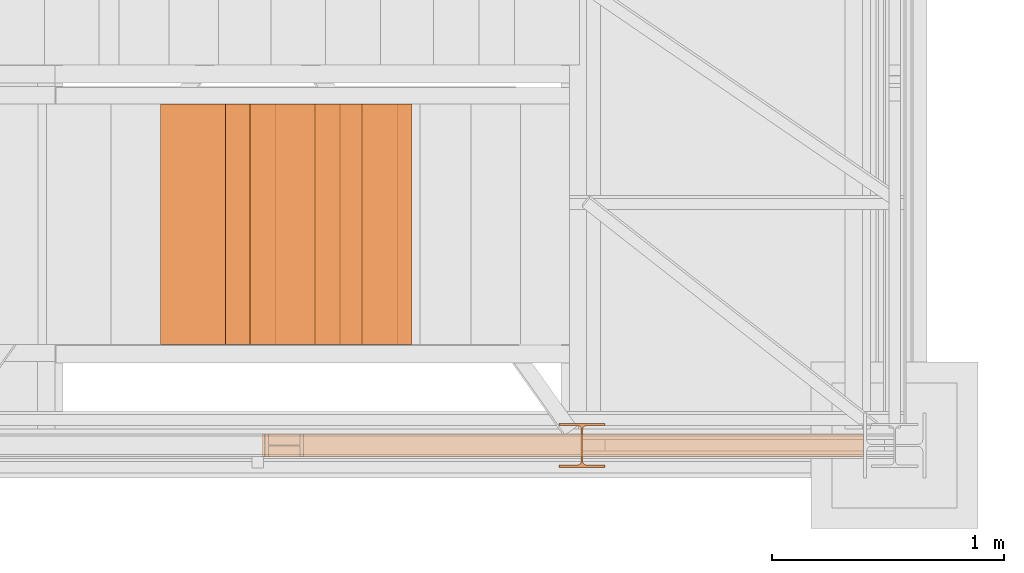
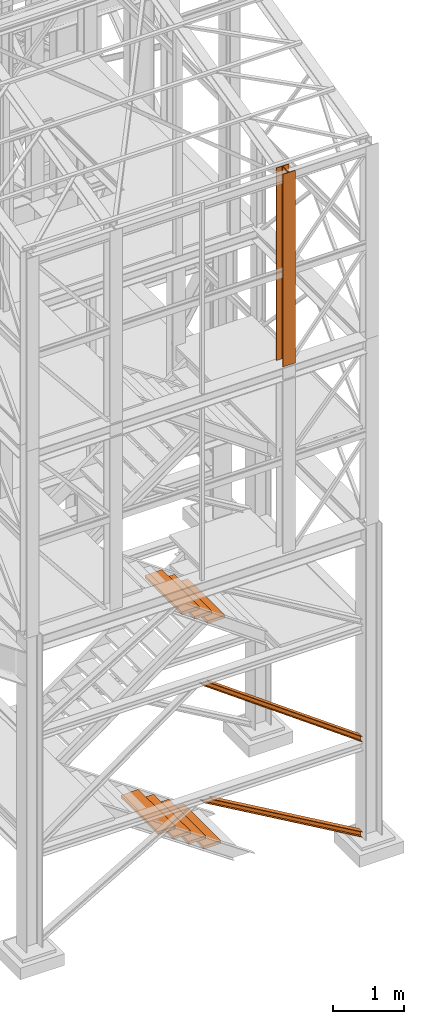
# One storey, part 44 of 208: 10 proxies.
"""IFC2X3 building model written with IfcOpenShell, lengths in millimetres."""

from ifc_helpers import new_model, entity, si_unit, converted_unit, frame, origin, origin_with_axes, place, context, subcontext, project, spatial, faceted_brep, element, save


model = new_model("IFC2X3")

# Units and contexts
model_context = context("Model", 3, precision=1e-05, world=origin())
plan_context = context("Plan", 3, precision=1e-05, world=origin())
body_context = subcontext(model_context, "Body", "Model", "MODEL_VIEW")
ifc_project = project(units=[si_unit("LENGTHUNIT", "METRE", prefix="MILLI"), converted_unit("PLANEANGLEUNIT", "DEGREE", entity("IfcPlaneAngleMeasure", 0.0174532925199433), si_unit("PLANEANGLEUNIT", "RADIAN"), dimensions=[0, 0, 0, 0, 0, 0, 0]), si_unit("AREAUNIT", "SQUARE_METRE"), si_unit("VOLUMEUNIT", "CUBIC_METRE")], contexts=[model_context, plan_context])

# Building, storey
building_placement = place(None, origin())
building = spatial("IfcBuilding", under=ifc_project, at=building_placement, CompositionType="COMPLEX")
storey_placement = place(building_placement, origin_with_axes())
storey = spatial("IfcBuildingStorey", under=building, at=storey_placement, Name="Geschoss", CompositionType="ELEMENT")

# Proxies
proxy_1_placement = place(storey_placement, frame((4333.540323586694, -24736.51916887601, 4082.443433237497), z_axis=(0.0, 0.0, 1.0), x_axis=(1.0, 0.0, 0.0)))
element("IfcBuildingElementProxy", 1, at=proxy_1_placement, inside=storey, context=body_context, shape_type="Brep", body=[
    faceted_brep([(0.009999999999308784, 0.00999999999839929, 0.01000000000021828), (280.2746556316179, 0.00999999999839929, 0.01000000000021828), (280.2746556316179, 1037.717170711916, 0.01000000000021828), (0.009999999999308784, 1037.717170711916, 0.01000000000021828), (280.2746556316179, 0.00999999999839929, 50.01000000000022), (0.009999999999308784, 0.00999999999839929, 50.01000000000022), (0.009999999999308784, 1037.717170711916, 50.01000000000022), (280.2746556316179, 1037.717170711916, 50.01000000000022), (280.2746556316179, 0.00999999999839929, 0.01000000000021828), (0.009999999999308784, 0.00999999999839929, 0.01000000000021828), (0.009999999999308784, 0.00999999999839929, 50.01000000000022), (280.2746556316179, 0.00999999999839929, 50.01000000000022), (280.2746556316179, 1037.717170711916, 0.01000000000021828), (280.2746556316179, 0.00999999999839929, 0.01000000000021828), (280.2746556316179, 0.00999999999839929, 50.01000000000022), (280.2746556316179, 1037.717170711916, 50.01000000000022), (0.009999999999308784, 1037.717170711916, 0.01000000000021828), (280.2746556316179, 1037.717170711916, 0.01000000000021828), (280.2746556316179, 1037.717170711916, 50.01000000000022), (0.009999999999308784, 1037.717170711916, 50.01000000000022), (0.009999999999308784, 0.00999999999839929, 0.01000000000021828), (0.009999999999308784, 1037.717170711916, 0.01000000000021828), (0.009999999999308784, 1037.717170711916, 50.01000000000022), (0.009999999999308784, 0.00999999999839929, 50.01000000000022)], [[[0, 1, 2, 3]], [[4, 5, 6, 7]], [[8, 9, 10, 11]], [[12, 13, 14, 15]], [[16, 17, 18, 19]], [[20, 21, 22, 23]]], orient=[[False], [False], [False], [False], [False], [False]]),
])
for number, where, z_axis, x_axis in (
    (2, (3776.168126991691, -24736.51916887601, 579.9900010557138), (0.0, 0.0, 1.0), (1.0, 0.0, 0.0)),
    (3, (3528.947418020675, -24736.51916887601, 749.9900010557138), (0.0, 0.0, 1.0), (1.0, 0.0, 0.0)),
):
    element("IfcBuildingElementProxy", number, at=place(storey_placement, frame(where, z_axis=z_axis, x_axis=x_axis)), inside=storey, context=body_context, shape_type="Brep", body=[
        faceted_brep([(0.01000000000021828, 0.00999999999839929, 0.009999999999990905), (280.2746556316183, 0.00999999999839929, 0.009999999999990905), (280.2746556316183, 1037.717170711916, 0.009999999999990905), (0.01000000000021828, 1037.717170711916, 0.009999999999990905), (280.2746556316183, 0.00999999999839929, 50.00999999999999), (0.01000000000021828, 0.00999999999839929, 50.00999999999999), (0.01000000000021828, 1037.717170711916, 50.00999999999999), (280.2746556316183, 1037.717170711916, 50.00999999999999), (280.2746556316183, 0.00999999999839929, 0.009999999999990905), (0.01000000000021828, 0.00999999999839929, 0.009999999999990905), (0.01000000000021828, 0.00999999999839929, 50.00999999999999), (280.2746556316183, 0.00999999999839929, 50.00999999999999), (280.2746556316183, 1037.717170711916, 0.009999999999990905), (280.2746556316183, 0.00999999999839929, 0.009999999999990905), (280.2746556316183, 0.00999999999839929, 50.00999999999999), (280.2746556316183, 1037.717170711916, 50.00999999999999), (0.01000000000021828, 1037.717170711916, 0.009999999999990905), (280.2746556316183, 1037.717170711916, 0.009999999999990905), (280.2746556316183, 1037.717170711916, 50.00999999999999), (0.01000000000021828, 1037.717170711916, 50.00999999999999), (0.01000000000021828, 0.00999999999839929, 0.009999999999990905), (0.01000000000021828, 1037.717170711916, 0.009999999999990905), (0.01000000000021828, 1037.717170711916, 50.00999999999999), (0.01000000000021828, 0.00999999999839929, 50.00999999999999)], [[[0, 1, 2, 3]], [[4, 5, 6, 7]], [[8, 9, 10, 11]], [[12, 13, 14, 15]], [[16, 17, 18, 19]], [[20, 21, 22, 23]]], orient=[[False], [False], [False], [False], [False], [False]]),
    ])
for number, where, z_axis, x_axis in (
    (4, (4023.388835962709, -24736.51916887601, 409.9900010557138), (0.0, 0.0, 1.0), (1.0, 0.0, 0.0)),
    (5, (4270.609544933726, -24736.51916887601, 239.9900010557138), (0.0, 0.0, 1.0), (1.0, 0.0, 0.0)),
):
    element("IfcBuildingElementProxy", number, at=place(storey_placement, frame(where, z_axis=z_axis, x_axis=x_axis)), inside=storey, context=body_context, shape_type="Brep", body=[
        faceted_brep([(0.009999999999308784, 0.00999999999839929, 0.009999999999990905), (280.2746556316179, 0.00999999999839929, 0.009999999999990905), (280.2746556316179, 1037.717170711916, 0.009999999999990905), (0.009999999999308784, 1037.717170711916, 0.009999999999990905), (280.2746556316179, 0.00999999999839929, 50.00999999999999), (0.009999999999308784, 0.00999999999839929, 50.00999999999999), (0.009999999999308784, 1037.717170711916, 50.00999999999999), (280.2746556316179, 1037.717170711916, 50.00999999999999), (280.2746556316179, 0.00999999999839929, 0.009999999999990905), (0.009999999999308784, 0.00999999999839929, 0.009999999999990905), (0.009999999999308784, 0.00999999999839929, 50.00999999999999), (280.2746556316179, 0.00999999999839929, 50.00999999999999), (280.2746556316179, 1037.717170711916, 0.009999999999990905), (280.2746556316179, 0.00999999999839929, 0.009999999999990905), (280.2746556316179, 0.00999999999839929, 50.00999999999999), (280.2746556316179, 1037.717170711916, 50.00999999999999), (0.009999999999308784, 1037.717170711916, 0.009999999999990905), (280.2746556316179, 1037.717170711916, 0.009999999999990905), (280.2746556316179, 1037.717170711916, 50.00999999999999), (0.009999999999308784, 1037.717170711916, 50.00999999999999), (0.009999999999308784, 0.00999999999839929, 0.009999999999990905), (0.009999999999308784, 1037.717170711916, 0.009999999999990905), (0.009999999999308784, 1037.717170711916, 50.00999999999999), (0.009999999999308784, 0.00999999999839929, 50.00999999999999)], [[[0, 1, 2, 3]], [[4, 5, 6, 7]], [[8, 9, 10, 11]], [[12, 13, 14, 15]], [[16, 17, 18, 19]], [[20, 21, 22, 23]]], orient=[[False], [False], [False], [False], [False], [False]]),
    ])
proxy_2_placement = place(storey_placement, frame((4117.985395275855, -24736.51916887601, 4230.607939364498), z_axis=(0.0, 0.0, 1.0), x_axis=(1.0, 0.0, 0.0)))
element("IfcBuildingElementProxy", 6, at=proxy_2_placement, inside=storey, context=body_context, shape_type="Brep", body=[
    faceted_brep([(0.009999999999308784, 0.00999999999839929, 0.01000000000021828), (280.2746556316179, 0.00999999999839929, 0.01000000000021828), (280.2746556316179, 1037.717170711916, 0.01000000000021828), (0.009999999999308784, 1037.717170711916, 0.01000000000021828), (280.2746556316179, 0.00999999999839929, 50.01000000000022), (0.009999999999308784, 0.00999999999839929, 50.01000000000022), (0.009999999999308784, 1037.717170711916, 50.01000000000022), (280.2746556316179, 1037.717170711916, 50.01000000000022), (280.2746556316179, 0.00999999999839929, 0.01000000000021828), (0.009999999999308784, 0.00999999999839929, 0.01000000000021828), (0.009999999999308784, 0.00999999999839929, 50.01000000000022), (280.2746556316179, 0.00999999999839929, 50.01000000000022), (280.2746556316179, 1037.717170711916, 0.01000000000021828), (280.2746556316179, 0.00999999999839929, 0.01000000000021828), (280.2746556316179, 0.00999999999839929, 50.01000000000022), (280.2746556316179, 1037.717170711916, 50.01000000000022), (0.009999999999308784, 1037.717170711916, 0.01000000000021828), (280.2746556316179, 1037.717170711916, 0.01000000000021828), (280.2746556316179, 1037.717170711916, 50.01000000000022), (0.009999999999308784, 1037.717170711916, 50.01000000000022), (0.009999999999308784, 0.00999999999839929, 0.01000000000021828), (0.009999999999308784, 1037.717170711916, 0.01000000000021828), (0.009999999999308784, 1037.717170711916, 50.01000000000022), (0.009999999999308784, 0.00999999999839929, 50.01000000000022)], [[[0, 1, 2, 3]], [[4, 5, 6, 7]], [[8, 9, 10, 11]], [[12, 13, 14, 15]], [[16, 17, 18, 19]], [[20, 21, 22, 23]]], orient=[[False], [False], [False], [False], [False], [False]]),
])
proxy_3_placement = place(storey_placement, frame((3914.355186072308, -24736.51916887601, 4381.076988578996), z_axis=(0.0, 0.0, 1.0), x_axis=(1.0, 0.0, 0.0)))
element("IfcBuildingElementProxy", 7, at=proxy_3_placement, inside=storey, context=body_context, shape_type="Brep", body=[
    faceted_brep([(0.01000000000021828, 0.00999999999839929, 0.01000000000021828), (280.2746556316188, 0.00999999999839929, 0.01000000000021828), (280.2746556316188, 1037.717170711916, 0.01000000000021828), (0.01000000000021828, 1037.717170711916, 0.01000000000021828), (280.2746556316188, 0.00999999999839929, 50.01000000000022), (0.01000000000021828, 0.00999999999839929, 50.01000000000022), (0.01000000000021828, 1037.717170711916, 50.01000000000022), (280.2746556316188, 1037.717170711916, 50.01000000000022), (280.2746556316188, 0.00999999999839929, 0.01000000000021828), (0.01000000000021828, 0.00999999999839929, 0.01000000000021828), (0.01000000000021828, 0.00999999999839929, 50.01000000000022), (280.2746556316188, 0.00999999999839929, 50.01000000000022), (280.2746556316188, 1037.717170711916, 0.01000000000021828), (280.2746556316188, 0.00999999999839929, 0.01000000000021828), (280.2746556316188, 0.00999999999839929, 50.01000000000022), (280.2746556316188, 1037.717170711916, 50.01000000000022), (0.01000000000021828, 1037.717170711916, 0.01000000000021828), (280.2746556316188, 1037.717170711916, 0.01000000000021828), (280.2746556316188, 1037.717170711916, 50.01000000000022), (0.01000000000021828, 1037.717170711916, 50.01000000000022), (0.01000000000021828, 0.00999999999839929, 0.01000000000021828), (0.01000000000021828, 1037.717170711916, 0.01000000000021828), (0.01000000000021828, 1037.717170711916, 50.01000000000022), (0.01000000000021828, 0.00999999999839929, 50.01000000000022)], [[[0, 1, 2, 3]], [[4, 5, 6, 7]], [[8, 9, 10, 11]], [[12, 13, 14, 15]], [[16, 17, 18, 19]], [[20, 21, 22, 23]]], orient=[[False], [False], [False], [False], [False], [False]]),
])
proxy_4_placement = place(storey_placement, frame((5248.254967038542, -25267.57439657637, 8484.990002086155), z_axis=(0.0, 0.0, 1.0), x_axis=(1.0, 0.0, 0.0)))
element("IfcBuildingElementProxy", 8, at=proxy_4_placement, inside=storey, context=body_context, shape_type="Brep", body=[
    faceted_brep([(0.01000000000021828, 190.010021192018, 3300.392426689976), (200.0100029802325, 190.010021192018, 3300.392426689976), (200.0100029802325, 180.0100232781806, 3300.392426689976), (121.2600035762789, 180.0100158276, 3300.392426689976), (111.9441915473344, 178.1454707803168, 3300.392426689976), (105.1245498640838, 171.3258277000823, 3300.392426689976), (103.2600015571716, 162.0100166024604, 3300.392426689976), (103.2600015571716, 28.01000581401968, 3300.392426689976), (105.1245498640838, 18.69419471639776, 3300.392426689976), (111.9441915473344, 11.87455163616323, 3300.392426689976), (121.2600035762789, 10.01000658888006, 3300.392426689976), (200.0100029802325, 10.01000658888006, 3300.392426689976), (200.0100029802325, 0.01000867504262715, 3300.392426689976), (0.01000000000021828, 0.01000867504262715, 3300.392426689976), (0.01000000000021828, 10.01000658888006, 3300.392426689976), (78.75999940395377, 10.01000658888006, 3300.392426689976), (88.07581143289826, 11.87455163616323, 3300.392426689976), (94.89545311614893, 18.69419471639776, 3300.392426689976), (96.76000142306111, 28.01000581401968, 3300.392426689976), (96.76000142306111, 162.0100166024604, 3300.392426689976), (94.89545311614893, 171.3258277000823, 3300.392426689976), (88.07581143289826, 178.1454707803168, 3300.392426689976), (78.75999940395377, 180.0100158276, 3300.392426689976), (0.01000000000021828, 180.0100232781806, 3300.392426689976), (200.0100029802325, 190.010021192018, 3300.392426689976), (0.01000000000021828, 190.010021192018, 3300.392426689976), (0.01000000000021828, 190.0100125169738, 0.01000000000021828), (200.0100029802325, 190.0100125169738, 0.01000000000021828), (200.0100029802325, 180.0100232781806, 3300.392426689976), (200.0100029802325, 190.010021192018, 3300.392426689976), (200.0100029802325, 190.0100125169738, 0.01000000000021828), (200.0100029802325, 180.0100146031364, 0.01000000000021828), (121.2600035762789, 180.0100158276, 3300.392426689976), (200.0100029802325, 180.0100232781806, 3300.392426689976), (200.0100029802325, 180.0100146031364, 0.01000000000021828), (121.2600035762789, 180.0100071525558, 0.01000000000021828), (111.9441915473344, 178.1454707803168, 3300.392426689976), (121.2600035762789, 180.0100158276, 3300.392426689976), (121.2600035762789, 180.0100071525558, 0.01000000000021828), (111.9441915473344, 178.1454621052726, 0.01000000000021828), (105.1245498640838, 171.3258277000823, 3300.392426689976), (111.9441915473344, 178.1454707803168, 3300.392426689976), (111.9441915473344, 178.1454621052726, 0.01000000000021828), (105.1245498640838, 171.3258190250381, 0.01000000000021828), (103.2600015571716, 162.0100166024604, 3300.392426689976), (105.1245498640838, 171.3258277000823, 3300.392426689976), (105.1245498640838, 171.3258190250381, 0.01000000000021828), (103.2600015571716, 162.0100079274162, 0.01000000000021828), (103.2600015571716, 28.01000581401968, 3300.392426689976), (103.2600015571716, 162.0100166024604, 3300.392426689976), (103.2600015571716, 162.0100079274162, 0.01000000000021828), (103.2600015571716, 28.00999713897545, 0.01000000000021828), (105.1245498640838, 18.69419471639776, 3300.392426689976), (103.2600015571716, 28.01000581401968, 3300.392426689976), (103.2600015571716, 28.00999713897545, 0.01000000000021828), (105.1245498640838, 18.69418604135353, 0.01000000000021828), (111.9441915473344, 11.87455163616323, 3300.392426689976), (105.1245498640838, 18.69419471639776, 3300.392426689976), (105.1245498640838, 18.69418604135353, 0.01000000000021828), (111.9441915473344, 11.87454296111901, 0.01000000000021828), (121.2600035762789, 10.01000658888006, 3300.392426689976), (111.9441915473344, 11.87455163616323, 3300.392426689976), (111.9441915473344, 11.87454296111901, 0.01000000000021828), (121.2600035762789, 10.00999791383583, 0.01000000000021828), (200.0100029802325, 10.01000658888006, 3300.392426689976), (121.2600035762789, 10.01000658888006, 3300.392426689976), (121.2600035762789, 10.00999791383583, 0.01000000000021828), (200.0100029802325, 10.00999791383583, 0.01000000000021828), (200.0100029802325, 0.01000867504262715, 3300.392426689976), (200.0100029802325, 10.01000658888006, 3300.392426689976), (200.0100029802325, 10.00999791383583, 0.01000000000021828), (200.0100029802325, 0.00999999999839929, 0.01000000000021828), (0.01000000000021828, 0.01000867504262715, 3300.392426689976), (200.0100029802325, 0.01000867504262715, 3300.392426689976), (200.0100029802325, 0.00999999999839929, 0.01000000000021828), (0.01000000000021828, 0.00999999999839929, 0.01000000000021828), (0.01000000000021828, 10.01000658888006, 3300.392426689976), (0.01000000000021828, 0.01000867504262715, 3300.392426689976), (0.01000000000021828, 0.00999999999839929, 0.01000000000021828), (0.01000000000021828, 10.00999791383583, 0.01000000000021828), (78.75999940395377, 10.01000658888006, 3300.392426689976), (0.01000000000021828, 10.01000658888006, 3300.392426689976), (0.01000000000021828, 10.00999791383583, 0.01000000000021828), (78.75999940395377, 10.00999791383583, 0.01000000000021828), (88.07581143289826, 11.87455163616323, 3300.392426689976), (78.75999940395377, 10.01000658888006, 3300.392426689976), (78.75999940395377, 10.00999791383583, 0.01000000000021828), (88.07581143289826, 11.87454296111901, 0.01000000000021828), (94.89545311614893, 18.69419471639776, 3300.392426689976), (88.07581143289826, 11.87455163616323, 3300.392426689976), (88.07581143289826, 11.87454296111901, 0.01000000000021828), (94.89545311614893, 18.69418604135353, 0.01000000000021828), (96.76000142306111, 28.01000581401968, 3300.392426689976), (94.89545311614893, 18.69419471639776, 3300.392426689976), (94.89545311614893, 18.69418604135353, 0.01000000000021828), (96.76000142306111, 28.00999713897545, 0.01000000000021828), (96.76000142306111, 162.0100166024604, 3300.392426689976), (96.76000142306111, 28.01000581401968, 3300.392426689976), (96.76000142306111, 28.00999713897545, 0.01000000000021828), (96.76000142306111, 162.0100079274162, 0.01000000000021828), (94.89545311614893, 171.3258277000823, 3300.392426689976), (96.76000142306111, 162.0100166024604, 3300.392426689976), (96.76000142306111, 162.0100079274162, 0.01000000000021828), (94.89545311614893, 171.3258190250381, 0.01000000000021828), (88.07581143289826, 178.1454707803168, 3300.392426689976), (94.89545311614893, 171.3258277000823, 3300.392426689976), (94.89545311614893, 171.3258190250381, 0.01000000000021828), (88.07581143289826, 178.1454621052726, 0.01000000000021828), (78.75999940395377, 180.0100158276, 3300.392426689976), (88.07581143289826, 178.1454707803168, 3300.392426689976), (88.07581143289826, 178.1454621052726, 0.01000000000021828), (78.75999940395377, 180.0100071525558, 0.01000000000021828), (0.01000000000021828, 180.0100232781806, 3300.392426689976), (78.75999940395377, 180.0100158276, 3300.392426689976), (78.75999940395377, 180.0100071525558, 0.01000000000021828), (0.01000000000021828, 180.0100146031364, 0.01000000000021828), (0.01000000000021828, 190.010021192018, 3300.392426689976), (0.01000000000021828, 180.0100232781806, 3300.392426689976), (0.01000000000021828, 180.0100146031364, 0.01000000000021828), (0.01000000000021828, 190.0100125169738, 0.01000000000021828), (0.01000000000021828, 190.0100125169738, 0.01000000000021828), (0.01000000000021828, 180.0100146031364, 0.01000000000021828), (78.75999940395377, 180.0100071525558, 0.01000000000021828), (88.07581143289826, 178.1454621052726, 0.01000000000021828), (94.89545311614893, 171.3258190250381, 0.01000000000021828), (96.76000142306111, 162.0100079274162, 0.01000000000021828), (96.76000142306111, 28.00999713897545, 0.01000000000021828), (94.89545311614893, 18.69418604135353, 0.01000000000021828), (88.07581143289826, 11.87454296111901, 0.01000000000021828), (78.75999940395377, 10.00999791383583, 0.01000000000021828), (0.01000000000021828, 10.00999791383583, 0.01000000000021828), (0.01000000000021828, 0.00999999999839929, 0.01000000000021828), (200.0100029802325, 0.00999999999839929, 0.01000000000021828), (200.0100029802325, 10.00999791383583, 0.01000000000021828), (121.2600035762789, 10.00999791383583, 0.01000000000021828), (111.9441915473344, 11.87454296111901, 0.01000000000021828), (105.1245498640838, 18.69418604135353, 0.01000000000021828), (103.2600015571716, 28.00999713897545, 0.01000000000021828), (103.2600015571716, 162.0100079274162, 0.01000000000021828), (105.1245498640838, 171.3258190250381, 0.01000000000021828), (111.9441915473344, 178.1454621052726, 0.01000000000021828), (121.2600035762789, 180.0100071525558, 0.01000000000021828), (200.0100029802325, 180.0100146031364, 0.01000000000021828), (200.0100029802325, 190.0100125169738, 0.01000000000021828)], [[[0, 1, 2, 3, 4, 5, 6, 7, 8, 9, 10, 11, 12, 13, 14, 15, 16, 17, 18, 19, 20, 21, 22, 23]], [[24, 25, 26, 27]], [[28, 29, 30, 31]], [[32, 33, 34, 35]], [[36, 37, 38, 39]], [[40, 41, 42, 43]], [[44, 45, 46, 47]], [[48, 49, 50, 51]], [[52, 53, 54, 55]], [[56, 57, 58, 59]], [[60, 61, 62, 63]], [[64, 65, 66, 67]], [[68, 69, 70, 71]], [[72, 73, 74, 75]], [[76, 77, 78, 79]], [[80, 81, 82, 83]], [[84, 85, 86, 87]], [[88, 89, 90, 91]], [[92, 93, 94, 95]], [[96, 97, 98, 99]], [[100, 101, 102, 103]], [[104, 105, 106, 107]], [[108, 109, 110, 111]], [[112, 113, 114, 115]], [[116, 117, 118, 119]], [[120, 121, 122, 123, 124, 125, 126, 127, 128, 129, 130, 131, 132, 133, 134, 135, 136, 137, 138, 139, 140, 141, 142, 143]]], orient=[[False], [False], [False], [False], [False], [False], [False], [False], [False], [False], [False], [False], [False], [False], [False], [False], [False], [False], [False], [False], [False], [False], [False], [False], [False], [False]]),
])
proxy_5_placement = place(storey_placement, frame((3966.37953388816, -25222.57439031789, 1566.490000221248), z_axis=(0.0, 0.0, 1.0), x_axis=(1.0, 0.0, 0.0)))
element("IfcBuildingElementProxy", 9, at=proxy_5_placement, inside=storey, context=body_context, shape_type="Brep", body=[
    faceted_brep([(2596.885429276088, 0.00999999999839929, 88.00999999999999), (2596.885429276088, 0.00999999999839929, 96.00999999999999), (2596.885429276088, 100.0099999999984, 96.00999999999999), (2596.885429276088, 100.0099999999984, 88.00999999999999), (2596.885429276088, 52.5099999999984, 88.00999999999999), (2596.885429276088, 52.5099999999984, 8.009999999999991), (2596.885429276088, 100.0099999999984, 8.009999999999991), (2596.885429276088, 100.0099999999984, 0.009999999999990905), (2596.885429276088, 0.00999999999839929, 0.009999999999990905), (2596.885429276088, 0.00999999999839929, 8.009999999999991), (2596.885429276088, 47.5099999999984, 8.009999999999991), (2596.885429276088, 47.5099999999984, 88.00999999999999), (2596.885429276088, 0.00999999999839929, 96.00999999999999), (2596.885429276088, 0.00999999999839929, 88.00999999999999), (121.5012482379625, 0.01000000000567525, 1881.009998688699), (132.5459071686873, 0.01000000000567525, 1881.009998688699), (2596.885429276088, 100.0099999999984, 96.00999999999999), (2596.885429276088, 0.00999999999839929, 96.00999999999999), (132.5459071686873, 0.01000000000567525, 1881.009998688699), (132.5459071686864, 100.0100000000057, 1881.009998688699), (2596.885429276088, 100.0099999999984, 88.00999999999999), (2596.885429276088, 100.0099999999984, 96.00999999999999), (132.5459071686864, 100.0100000000057, 1881.009998688699), (121.5012482379625, 100.010000000002, 1881.009998688699), (2596.885429276088, 52.5099999999984, 88.00999999999999), (2596.885429276088, 100.0099999999984, 88.00999999999999), (121.5012482379625, 100.010000000002, 1881.009998688699), (121.5012482379625, 52.51000000000568, 1881.009998688699), (2596.885429276088, 52.5099999999984, 8.009999999999991), (2596.885429276088, 52.5099999999984, 88.00999999999999), (121.5012482379625, 52.51000000000568, 1881.009998688699), (11.05465893072415, 52.51000000000568, 1881.009998688699), (2596.885429276088, 100.0099999999984, 8.009999999999991), (2596.885429276088, 52.5099999999984, 8.009999999999991), (11.05465893072415, 52.51000000000568, 1881.009998688699), (11.05465893072415, 100.0100000000057, 1881.009998688699), (2596.885429276088, 100.0099999999984, 0.009999999999990905), (2596.885429276088, 100.0099999999984, 8.009999999999991), (11.05465893072415, 100.0100000000057, 1881.009998688699), (0.01000000000021828, 100.0100000000057, 1881.009998688699), (2596.885429276088, 0.00999999999839929, 0.009999999999990905), (2596.885429276088, 100.0099999999984, 0.009999999999990905), (0.01000000000021828, 100.0100000000057, 1881.009998688699), (0.01000000000021828, 0.01000000000567525, 1881.009998688699), (2596.885429276088, 0.00999999999839929, 8.009999999999991), (2596.885429276088, 0.00999999999839929, 0.009999999999990905), (0.01000000000021828, 0.01000000000567525, 1881.009998688699), (11.05465893072415, 0.01000000000203727, 1881.009998688699), (2596.885429276088, 47.5099999999984, 8.009999999999991), (2596.885429276088, 0.00999999999839929, 8.009999999999991), (11.05465893072415, 0.01000000000203727, 1881.009998688699), (11.05465893072324, 47.51000000000568, 1881.0099986887), (2596.885429276088, 47.5099999999984, 88.00999999999999), (2596.885429276088, 47.5099999999984, 8.009999999999991), (11.05465893072324, 47.51000000000568, 1881.0099986887), (121.5012482379625, 47.51000000000568, 1881.009998688699), (2596.885429276088, 0.00999999999839929, 88.00999999999999), (2596.885429276088, 47.5099999999984, 88.00999999999999), (121.5012482379625, 47.51000000000568, 1881.009998688699), (121.5012482379625, 0.01000000000567525, 1881.009998688699), (121.5012482379625, 0.01000000000567525, 1881.009998688699), (121.5012482379625, 47.51000000000568, 1881.009998688699), (11.05465893072324, 47.51000000000568, 1881.0099986887), (11.05465893072415, 0.01000000000203727, 1881.009998688699), (0.01000000000021828, 0.01000000000567525, 1881.009998688699), (0.01000000000021828, 100.0100000000057, 1881.009998688699), (11.05465893072415, 100.0100000000057, 1881.009998688699), (11.05465893072415, 52.51000000000568, 1881.009998688699), (121.5012482379625, 52.51000000000568, 1881.009998688699), (121.5012482379625, 100.010000000002, 1881.009998688699), (132.5459071686864, 100.0100000000057, 1881.009998688699), (132.5459071686873, 0.01000000000567525, 1881.009998688699)], [[[0, 1, 2, 3, 4, 5, 6, 7, 8, 9, 10, 11]], [[12, 13, 14, 15]], [[16, 17, 18, 19]], [[20, 21, 22, 23]], [[24, 25, 26, 27]], [[28, 29, 30, 31]], [[32, 33, 34, 35]], [[36, 37, 38, 39]], [[40, 41, 42, 43]], [[44, 45, 46, 47]], [[48, 49, 50, 51]], [[52, 53, 54, 55]], [[56, 57, 58, 59]], [[60, 61, 62, 63, 64, 65, 66, 67, 68, 69, 70, 71]]], orient=[[False], [False], [False], [False], [False], [False], [False], [False], [False], [False], [False], [False], [False], [False]]),
])
proxy_6_placement = place(storey_placement, frame((3980.145216676689, -25222.57439031789, -65.00999999999999), z_axis=(0.0, 0.0, 1.0), x_axis=(1.0, 0.0, 0.0)))
element("IfcBuildingElementProxy", 10, at=proxy_6_placement, inside=storey, context=body_context, shape_type="Brep", body=[
    faceted_brep([(2583.11974648756, 0.00999999999839929, 88.00999999999999), (2583.11974648756, 0.00999999999839929, 96.00999999999999), (2583.11974648756, 100.0099999999984, 96.00999999999999), (2583.11974648756, 100.0099999999984, 88.00999999999999), (2583.11974648756, 52.5099999999984, 88.00999999999999), (2583.11974648756, 52.5099999999984, 8.009999999999991), (2583.11974648756, 100.0099999999984, 8.009999999999991), (2583.11974648756, 100.0099999999984, 0.009999999999990905), (2583.11974648756, 0.00999999999839929, 0.009999999999990905), (2583.11974648756, 0.00999999999839929, 8.009999999999991), (2583.11974648756, 47.5099999999984, 8.009999999999991), (2583.11974648756, 47.5099999999984, 88.00999999999999), (2583.11974648756, 0.00999999999839929, 96.00999999999999), (2583.11974648756, 0.00999999999839929, 88.00999999999999), (151.704132703544, 0.01000000000567525, 1498.509998909946), (165.4945084038664, 0.01000000000567525, 1498.509998909946), (2583.11974648756, 100.0099999999984, 96.00999999999999), (2583.11974648756, 0.00999999999839929, 96.00999999999999), (165.4945084038664, 0.01000000000567525, 1498.509998909946), (165.4945084038664, 100.010000000002, 1498.509998909947), (2583.11974648756, 100.0099999999984, 88.00999999999999), (2583.11974648756, 100.0099999999984, 96.00999999999999), (165.4945084038664, 100.010000000002, 1498.509998909947), (151.704132703544, 100.0100000000057, 1498.509998909946), (2583.11974648756, 52.5099999999984, 88.00999999999999), (2583.11974648756, 100.0099999999984, 88.00999999999999), (151.704132703544, 100.0100000000057, 1498.509998909946), (151.704132703544, 52.51000000000204, 1498.509998909946), (2583.11974648756, 52.5099999999984, 8.009999999999991), (2583.11974648756, 52.5099999999984, 88.00999999999999), (151.704132703544, 52.51000000000204, 1498.509998909946), (13.80037570032346, 52.51000000000568, 1498.509998909946), (2583.11974648756, 100.0099999999984, 8.009999999999991), (2583.11974648756, 52.5099999999984, 8.009999999999991), (13.80037570032346, 52.51000000000568, 1498.509998909946), (13.80037570032346, 100.0100000000057, 1498.509998909946), (2583.11974648756, 100.0099999999984, 0.009999999999990905), (2583.11974648756, 100.0099999999984, 8.009999999999991), (13.80037570032346, 100.0100000000057, 1498.509998909946), (0.01000000000112777, 100.0100000000057, 1498.509998909946), (2583.11974648756, 0.00999999999839929, 0.009999999999990905), (2583.11974648756, 100.0099999999984, 0.009999999999990905), (0.01000000000112777, 100.0100000000057, 1498.509998909946), (0.01000000000021828, 0.01000000000567525, 1498.509998909947), (2583.11974648756, 0.00999999999839929, 8.009999999999991), (2583.11974648756, 0.00999999999839929, 0.009999999999990905), (0.01000000000021828, 0.01000000000567525, 1498.509998909947), (13.80037570032346, 0.01000000000567525, 1498.509998909946), (2583.11974648756, 47.5099999999984, 8.009999999999991), (2583.11974648756, 0.00999999999839929, 8.009999999999991), (13.80037570032346, 0.01000000000567525, 1498.509998909946), (13.80037570032346, 47.51000000000568, 1498.509998909946), (2583.11974648756, 47.5099999999984, 88.00999999999999), (2583.11974648756, 47.5099999999984, 8.009999999999991), (13.80037570032346, 47.51000000000568, 1498.509998909946), (151.704132703544, 47.51000000000568, 1498.509998909946), (2583.11974648756, 0.00999999999839929, 88.00999999999999), (2583.11974648756, 47.5099999999984, 88.00999999999999), (151.704132703544, 47.51000000000568, 1498.509998909946), (151.704132703544, 0.01000000000567525, 1498.509998909946), (151.704132703544, 0.01000000000567525, 1498.509998909946), (151.704132703544, 47.51000000000568, 1498.509998909946), (13.80037570032346, 47.51000000000568, 1498.509998909946), (13.80037570032346, 0.01000000000567525, 1498.509998909946), (0.01000000000021828, 0.01000000000567525, 1498.509998909947), (0.01000000000112777, 100.0100000000057, 1498.509998909946), (13.80037570032346, 100.0100000000057, 1498.509998909946), (13.80037570032346, 52.51000000000568, 1498.509998909946), (151.704132703544, 52.51000000000204, 1498.509998909946), (151.704132703544, 100.0100000000057, 1498.509998909946), (165.4945084038664, 100.010000000002, 1498.509998909947), (165.4945084038664, 0.01000000000567525, 1498.509998909946)], [[[0, 1, 2, 3, 4, 5, 6, 7, 8, 9, 10, 11]], [[12, 13, 14, 15]], [[16, 17, 18, 19]], [[20, 21, 22, 23]], [[24, 25, 26, 27]], [[28, 29, 30, 31]], [[32, 33, 34, 35]], [[36, 37, 38, 39]], [[40, 41, 42, 43]], [[44, 45, 46, 47]], [[48, 49, 50, 51]], [[52, 53, 54, 55]], [[56, 57, 58, 59]], [[60, 61, 62, 63, 64, 65, 66, 67, 68, 69, 70, 71]]], orient=[[False], [False], [False], [False], [False], [False], [False], [False], [False], [False], [False], [False], [False], [False]]),
])

save(model, "model.ifc")
